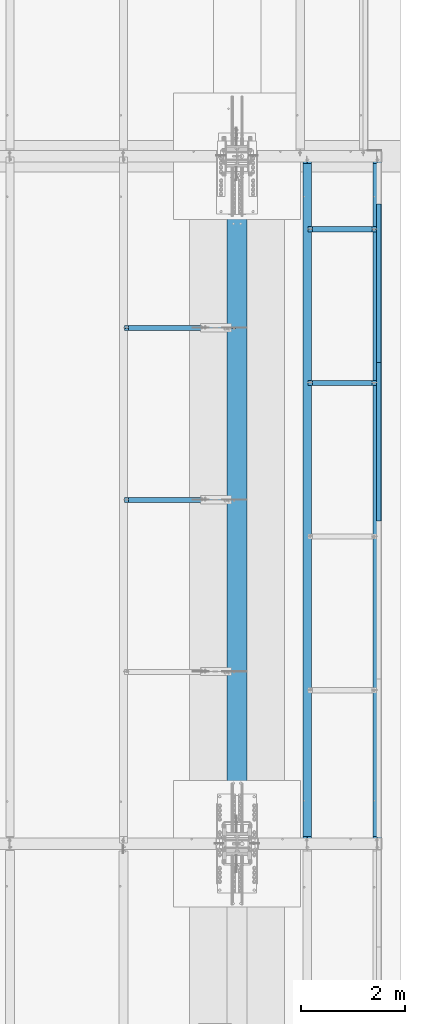
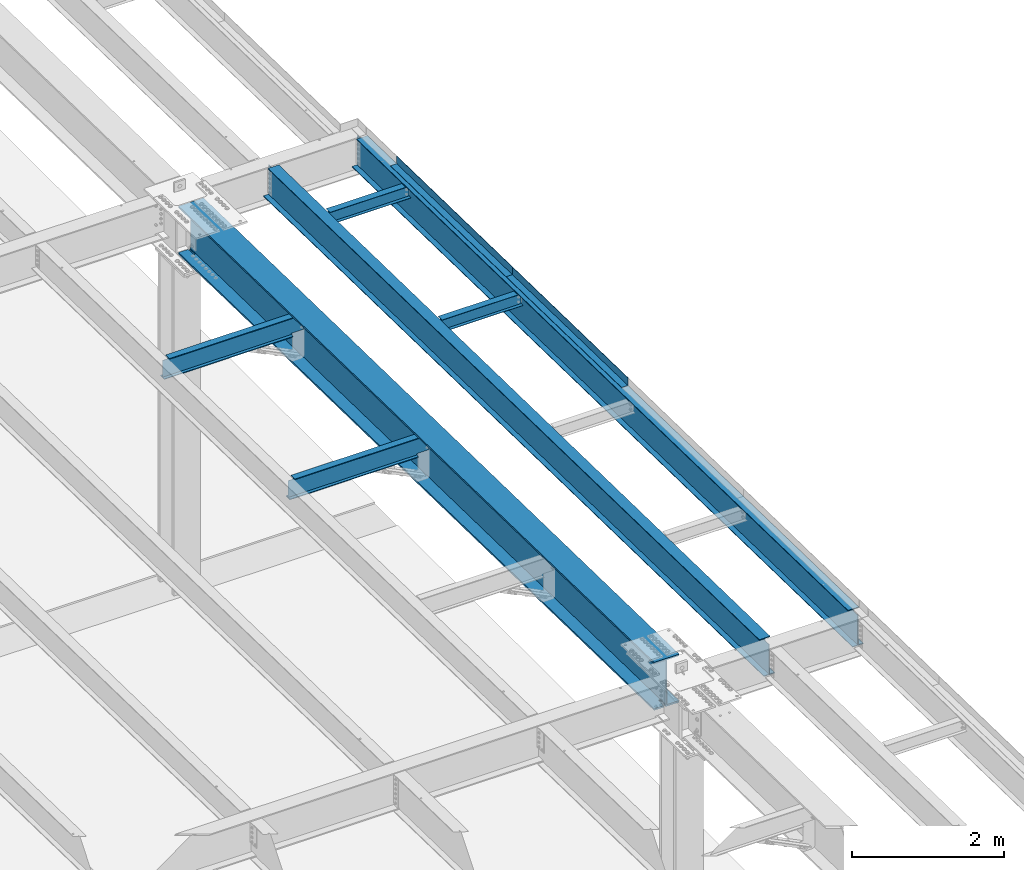
# One storey, part 1116 of 1763: 9 beams, 7 elements without a shape of their own.
"""IFC2X3 building model written with IfcOpenShell, lengths in millimetres."""

import ifcopenshell
import ifcopenshell.guid

model = None  # the IFC model being written
_history = None  # IfcOwnerHistory: only IFC2X3 demands one
_inside = {}  # id of a spatial element -> (the spatial element, [elements in it])
_under = {}  # id of a project, library or spatial element -> (it, [spatial elements below it])
_declared = {}  # id of a project -> (the project, [libraries it declares])
_typed = {}  # id of a type object -> (the type object, [elements of that type])
_made_of = {}  # id of a material, layer set ... -> (it, [elements and type objects made of it])


def new_model(schema):
    """Start an empty IFC model of exactly this schema.

    Asked for "IFC4X3", IfcOpenShell would pick the latest addendum, in which some entities
    have other attributes; the version numbers below select the first issue.
    IFC2X3 requires an IfcOwnerHistory on every rooted entity: one is made here for all.
    """
    global model, _history
    if schema == "IFC4X3":
        model = ifcopenshell.file(schema_version=(4, 3, 0, 0))
    else:
        model = ifcopenshell.file(schema=schema)
    _inside.clear()
    _under.clear()
    _declared.clear()
    _typed.clear()
    _made_of.clear()
    _history = None
    if model.schema == "IFC2X3":
        org = make("IfcOrganization", Name="unknown")
        user = make(
            "IfcPersonAndOrganization",
            ThePerson=make("IfcPerson", FamilyName="unknown"),
            TheOrganization=org,
        )
        app = make(
            "IfcApplication",
            ApplicationDeveloper=org,
            Version="unknown",
            ApplicationFullName="unknown",
            ApplicationIdentifier="unknown",
        )
        _history = make(
            "IfcOwnerHistory",
            OwningUser=user,
            OwningApplication=app,
            ChangeAction="ADDED",
            CreationDate=0,
        )
    return model


def make(cls, **values):
    """One entity of the class cls with the attributes given. An attribute that is None is left unset."""
    return model.create_entity(
        cls, **{name: value for name, value in values.items() if value is not None}
    )


def rooted(cls, **values):
    """An entity with a GlobalId (a new one), such as an element, a storey or a relation."""
    return make(cls, GlobalId=ifcopenshell.guid.new(), OwnerHistory=_history, **values)


def si_unit(unit_type, name, prefix=None):
    """IfcSIUnit, for example si_unit("LENGTHUNIT", "METRE", prefix="MILLI")."""
    return make("IfcSIUnit", UnitType=unit_type, Prefix=prefix, Name=name)


def assignment(units):
    """IfcUnitAssignment: the units of a project."""
    return None if units is None else make("IfcUnitAssignment", Units=units)


def point(xyz):
    """IfcCartesianPoint."""
    return None if xyz is None else make("IfcCartesianPoint", Coordinates=xyz)


def direction(xyz):
    """IfcDirection."""
    return None if xyz is None else make("IfcDirection", DirectionRatios=xyz)


def frame(location, z_axis=None, x_axis=None):
    """IfcAxis2Placement3D, a coordinate frame: its origin and axes. An axis left out is left unset."""
    return make(
        "IfcAxis2Placement3D",
        Location=point(location),
        Axis=direction(z_axis),
        RefDirection=direction(x_axis),
    )


def origin_with_axes():
    """The frame at (0, 0, 0) with the z axis (0, 0, 1) and the x axis (1, 0, 0) written out."""
    return frame((0.0, 0.0, 0.0), z_axis=(0.0, 0.0, 1.0), x_axis=(1.0, 0.0, 0.0))


def place(relative_to, where):
    """IfcLocalPlacement: puts the frame where relative to a parent placement (None: the world)."""
    return make(
        "IfcLocalPlacement", PlacementRelTo=relative_to, RelativePlacement=where
    )


def context(
    kind, dimensions, precision=None, world=None, true_north=None, identifier=None
):
    """IfcGeometricRepresentationContext, for example the 3D "Model" context."""
    return make(
        "IfcGeometricRepresentationContext",
        ContextIdentifier=identifier,
        ContextType=kind,
        CoordinateSpaceDimension=dimensions,
        Precision=precision,
        WorldCoordinateSystem=world,
        TrueNorth=true_north,
    )


def subcontext(parent, identifier, kind, view, scale=None):
    """IfcGeometricRepresentationSubContext, for example "Body" below "Model"."""
    return make(
        "IfcGeometricRepresentationSubContext",
        ContextIdentifier=identifier,
        ContextType=kind,
        ParentContext=parent,
        TargetScale=scale,
        TargetView=view,
    )


def project(units=None, contexts=None):
    """IfcProject with its units and contexts."""
    return rooted(
        "IfcProject",
        Name="project",
        RepresentationContexts=contexts,
        UnitsInContext=assignment(units),
    )


def spatial(cls, under=None, at=None, **own):
    """A site, building, storey or space (cls), placed at a placement, below another one or the project."""
    s = rooted(cls, ObjectPlacement=at, **own)
    if under is not None:
        _under.setdefault(under.id(), (under, []))[1].append(s)
    return s


def faces_of(points, faces, orient=None, outer=None):
    """IfcFace entities. A face is a list of loops; a loop is a list of indices into points, from 0.

    orient and outer hold one flag for each loop. By default every Orientation is true, the
    first loop of a face is its IfcFaceOuterBound and the others are IfcFaceBound.
    """
    made = []
    for i, loops in enumerate(faces):
        bounds = []
        for j, loop in enumerate(loops):
            is_outer = j == 0 if outer is None else outer[i][j]
            bounds.append(
                make(
                    "IfcFaceOuterBound" if is_outer else "IfcFaceBound",
                    Bound=make("IfcPolyLoop", Polygon=[points[k] for k in loop]),
                    Orientation=True if orient is None else orient[i][j],
                )
            )
        made.append(make("IfcFace", Bounds=bounds))
    return made


def faceted_brep(points, faces, orient=None, outer=None, voids=None):
    """IfcFacetedBrep: a solid bounded by flat faces; with voids (closed shells), ...WithVoids."""
    shared = [point(p) for p in points]
    hull = make("IfcClosedShell", CfsFaces=faces_of(shared, faces, orient, outer))
    if voids is None:
        return make("IfcFacetedBrep", Outer=hull)
    return make(
        "IfcFacetedBrepWithVoids",
        Outer=hull,
        Voids=[
            make(cls, CfsFaces=faces_of(shared, fs, o, b)) for cls, fs, o, b in voids
        ],
    )


def shape(context_of_items, identifier, shape_type, items):
    """IfcShapeRepresentation: the items that make up one representation, for example the "Body"."""
    return make(
        "IfcShapeRepresentation",
        ContextOfItems=context_of_items,
        RepresentationIdentifier=identifier,
        RepresentationType=shape_type,
        Items=items,
    )


def material(Name=None, Category=None):
    """IfcMaterial."""
    return make("IfcMaterial", Name=Name, Category=Category)


def made_of(thing, what):
    """Note that an element or type object is made of a material, layer set ...; save() writes the relation."""
    if what is not None:
        _made_of.setdefault(what.id(), (what, []))[1].append(thing)
    return thing


def type_object(cls, material=None, **own):
    """A type object (cls), such as IfcWallType, which elements share."""
    return made_of(rooted(cls, **own), material)


def element(
    cls,
    number,
    at=None,
    inside=None,
    cuts=None,
    type_object=None,
    material=None,
    context=None,
    identifier="Body",
    shape_type=None,
    held_by="IfcProductDefinitionShape",
    body=None,
    shapes=None,
    **own,
):
    """One element of the class cls, such as IfcWall. Its Tag is "e" and its number.

    at: its placement. inside: the storey or other place that contains it. cuts: it is an
    opening in that element (IfcRelVoidsElement). A single representation is given by context,
    identifier, shape_type and body (its items); several are given by shapes. held_by: the class
    of the entity that holds the representations. save() writes the other relations.
    """
    e = rooted(cls, Tag="e%d" % number, ObjectPlacement=at, **own)
    if body is not None:
        shapes = [shape(context, identifier, shape_type, body)]
    if shapes is not None:
        e.Representation = make(held_by, Representations=shapes)
    if inside is not None:
        _inside.setdefault(inside.id(), (inside, []))[1].append(e)
    if cuts is not None:
        rooted(
            "IfcRelVoidsElement", RelatingBuildingElement=cuts, RelatedOpeningElement=e
        )
    if type_object is not None:
        _typed.setdefault(type_object.id(), (type_object, []))[1].append(e)
    return made_of(e, material)


def aggregate(whole, parts):
    """IfcRelAggregates: a whole, such as a stair, and the parts it consists of."""
    return rooted("IfcRelAggregates", RelatingObject=whole, RelatedObjects=parts)


def save(model, path):
    """Write the relations noted so far, then the file.

    IfcRelAggregates (storeys below a building ...), IfcRelContainedInSpatialStructure (elements
    in a storey), IfcRelDefinesByType, IfcRelAssociatesMaterial and IfcRelDeclares: one each for
    every whole, place, type object, material and project.
    """
    for whole, parts in _under.values():
        aggregate(whole, parts)
    for where, things in _inside.values():
        rooted(
            "IfcRelContainedInSpatialStructure",
            RelatedElements=things,
            RelatingStructure=where,
        )
    for kind, things in _typed.values():
        rooted("IfcRelDefinesByType", RelatedObjects=things, RelatingType=kind)
    for what, things in _made_of.values():
        rooted("IfcRelAssociatesMaterial", RelatedObjects=things, RelatingMaterial=what)
    for by, libraries in _declared.values():
        rooted("IfcRelDeclares", RelatingContext=by, RelatedDefinitions=libraries)
    model.write(path)


model = new_model("IFC2X3")

# Units and contexts
model_context = context("Model", 3, precision=1e-05, world=origin_with_axes())
body_context = subcontext(model_context, "Body", "Model", "MODEL_VIEW")
ifc_project = project(units=[si_unit("LENGTHUNIT", "METRE", prefix="MILLI"), si_unit("AREAUNIT", "SQUARE_METRE"), si_unit("VOLUMEUNIT", "CUBIC_METRE"), si_unit("MASSUNIT", "GRAM", prefix="KILO"), si_unit("TIMEUNIT", "SECOND"), si_unit("PLANEANGLEUNIT", "RADIAN"), si_unit("SOLIDANGLEUNIT", "STERADIAN"), si_unit("THERMODYNAMICTEMPERATUREUNIT", "DEGREE_CELSIUS"), si_unit("LUMINOUSINTENSITYUNIT", "LUMEN")], contexts=[model_context])

# Site, building, storey
site_placement = place(None, origin_with_axes())
site = spatial("IfcSite", under=ifc_project, at=site_placement, CompositionType="ELEMENT")
building_placement = place(site_placement, origin_with_axes())
building = spatial("IfcBuilding", under=site, at=building_placement, Name="Undefined", CompositionType="ELEMENT")
storey_placement = place(building_placement, origin_with_axes())
storey = spatial("IfcBuildingStorey", under=building, at=storey_placement, Name="Undefined", CompositionType="ELEMENT", Elevation=0.0)

# Assembly, beams
assembly_1_placement = place(storey_placement, origin_with_axes())
assembly_1 = element("IfcElementAssembly", 1, at=assembly_1_placement, inside=storey, Name="BEAM", AssemblyPlace="NOTDEFINED", PredefinedType="RIGID_FRAME")
ifc_material_1 = material(Name="STEEL/A36")
beam_type_1 = type_object("IfcBeamType", PredefinedType="NOTDEFINED")
beam_1_placement = place(assembly_1_placement, frame((-21348.1372736983, 11243.5716910925, 11686.0728087312), z_axis=(0.0, -0.999781542838788, 0.0209013539966307), x_axis=(1.0, 0.0, 0.0)))
beam_1 = element("IfcBeam", 2, at=beam_1_placement, type_object=beam_type_1, material=ifc_material_1, Name="BENT_PLATE", context=body_context, shape_type="Brep", body=[
    faceted_brep([(0.0, -3.17499999999927, -1523.99999999999), (0.0, -3.17499999999927, 1524.0), (0.0, 3.17499999999927, 1524.0), (0.0, 3.17499999999927, -1523.99999999999), (95.2499984741262, 3.17499999910251, 1523.99999999978), (95.2499984741262, 3.17500000090149, -1523.99999999977), (101.599998474125, -3.17499999909887, -1523.99999999978), (101.599999809252, -3.17500000000655, 1524.0), (95.2499984741262, 123.825003587437, 1523.99999999985), (95.2499984741262, 123.825003589236, -1523.9999999997), (101.599998474125, 123.825003587437, 1523.99999999985), (101.599998474125, 123.825003589236, -1523.9999999997)], [[[0, 1, 2, 3]], [[3, 2, 4, 5]], [[1, 0, 6, 7]], [[5, 4, 8, 9]], [[4, 2, 1, 7, 10, 8]], [[7, 6, 11, 10]], [[6, 0, 3, 5, 9, 11]], [[10, 11, 9, 8]]]),
])
beam_2_placement = place(assembly_1_placement, frame((-21348.1372736983, 8196.23754864728, 11749.7801418084), z_axis=(0.0, -0.999781542838788, 0.0209013539966307), x_axis=(1.0, 0.0, 0.0)))
beam_2 = element("IfcBeam", 3, at=beam_2_placement, type_object=beam_type_1, material=ifc_material_1, Name="BENT_PLATE", context=body_context, shape_type="Brep", body=[
    faceted_brep([(0.0, -3.17499999999927, -1523.99999999999), (0.0, -3.17499999999927, 1524.0), (0.0, 3.17499999999927, 1524.0), (0.0, 3.17499999999927, -1523.99999999999), (95.2499984741262, 3.17499999910251, 1523.99999999978), (95.2499984741262, 3.17500000090149, -1523.99999999977), (101.599998474125, -3.17499999909887, -1523.99999999978), (101.599999809252, -3.17500000000655, 1524.0), (95.2499984741262, 123.825003587437, 1523.99999999985), (95.2499984741262, 123.825003589236, -1523.9999999997), (101.599998474125, 123.825003587437, 1523.99999999985), (101.599998474125, 123.825003589236, -1523.9999999997)], [[[0, 1, 2, 3]], [[3, 2, 4, 5]], [[1, 0, 6, 7]], [[5, 4, 8, 9]], [[4, 2, 1, 7, 10, 8]], [[7, 6, 11, 10]], [[6, 0, 3, 5, 9, 11]], [[10, 11, 9, 8]]]),
])

# Assembly, beam
assembly_2_placement = place(storey_placement, origin_with_axes())
assembly_2 = element("IfcElementAssembly", 4, at=assembly_2_placement, inside=storey, Name="BEAM", AssemblyPlace="NOTDEFINED", PredefinedType="RIGID_FRAME")
ifc_material_2 = material(Name="STEEL/A992")
beam_type_2 = type_object("IfcBeamType", Name="W8X10", PredefinedType="NOTDEFINED")
beam_3_placement = place(assembly_2_placement, frame((-22678.4622736983, 9326.87987676897, 11622.9548265527), z_axis=(0.0, 0.0, 1.0), x_axis=(1.0, 0.0, 0.0)))
beam_3 = element("IfcBeam", 5, at=beam_3_placement, type_object=beam_type_2, material=ifc_material_2, Name="BEAM", ObjectType="W8X10", context=body_context, shape_type="Brep", body=[
    faceted_brep([(1249.3625, -50.7999999999993, 100.012500000001), (1249.3625, -50.7999999999993, 95.25), (1249.3625, -2.38125000000036, 95.25), (1249.3625, -2.38124999999991, 83.8775014834882), (1249.3625, 2.38124999999991, 83.8775014834882), (1249.3625, 2.38125000000036, 95.25), (1249.3625, 50.7999999999993, 95.25), (1249.3625, 50.7999999999993, 100.012500000001), (1250.32922992259, -2.38124999999991, 79.0174219654418), (1250.32922992259, 2.38124999999991, 79.0174219654418), (1253.08224382306, -2.38124999999991, 74.8972454972882), (1253.08224382306, 2.38124999999991, 74.8972454972882), (1257.20242029122, -2.38124999999991, 72.1442315968106), (1257.20242029122, 2.38124999999991, 72.1442315968106), (1262.06249980926, -2.38124999999991, 71.1775016742231), (1262.06249980926, 2.38124999999991, 71.1775016742231), (1331.9125, -2.38124999999991, 71.1775016742231), (1331.9125, 2.38124999999991, 71.1775016742231), (100.012500000012, -50.7999999999993, 100.012500000001), (100.012500000012, 50.7999999999993, 100.012500000001), (100.012500000012, 50.7999999999993, 95.25), (100.012500000012, 2.38124999999854, 95.25), (100.012500000012, 2.38124999999854, 83.877501483119), (100.012500000012, -2.38124999999854, 83.877501483119), (100.012500000012, -2.38124999999854, 95.25), (100.012500000012, -50.7999999999993, 95.25), (99.0457700774241, 2.38124999999854, 79.0174219650726), (99.0457700774241, -2.38124999999854, 79.0174219650726), (96.2927561769466, 2.38124999999854, 74.8972454969189), (96.2927561769466, -2.38124999999854, 74.8972454969189), (92.1725797087929, 2.38124999999854, 72.1442315964414), (92.1725797087929, -2.38124999999854, 72.1442315964414), (87.3125001907465, 2.38124999999854, 71.1775016738538), (87.3125001907465, -2.38124999999854, 71.1775016738538), (17.4625000000015, 2.38124999999854, 71.1775016738538), (17.4625000000015, -2.38124999999854, 71.1775016738538), (17.462499935149, 2.38124999999854, -95.25), (17.4625000000015, 50.7999999999993, -95.25), (17.4625000000015, 50.7999999999993, -100.012500000001), (17.4624996160601, -50.8000000000029, -100.012500000001), (17.4624996160601, -50.8000000000029, -95.25), (17.4624999065727, -2.38124999999854, -95.25), (1331.91249999999, 2.38125000000036, -95.25), (1331.91249999999, 50.7999999999993, -95.25), (1331.91249999999, 50.7999999999993, -100.012500000001), (1331.91249999999, -50.7999999999993, -100.012500000001), (1331.91249999999, -50.7999999999993, -95.25), (1331.91249999999, -2.38125000000036, -95.25)], [[[0, 1, 2, 3, 4, 5, 6, 7]], [[8, 9, 4, 3]], [[10, 11, 9, 8]], [[12, 13, 11, 10]], [[14, 15, 13, 12]], [[16, 17, 15, 14]], [[18, 19, 20, 21, 22, 23, 24, 25]], [[23, 22, 26, 27]], [[27, 26, 28, 29]], [[29, 28, 30, 31]], [[31, 30, 32, 33]], [[33, 32, 34, 35]], [[36, 37, 38, 39, 40, 41, 35, 34]], [[37, 36, 42, 43]], [[38, 37, 43, 44]], [[39, 38, 44, 45]], [[40, 39, 45, 46]], [[41, 40, 46, 47]], [[12, 10, 8, 3, 2, 24, 23, 27, 29, 31, 33, 35, 41, 47, 16, 14]], [[25, 24, 2, 1]], [[18, 25, 1, 0]], [[19, 18, 0, 7]], [[20, 19, 7, 6]], [[21, 20, 6, 5]], [[42, 36, 34, 32, 30, 28, 26, 22, 21, 5, 4, 9, 11, 13, 15, 17]], [[47, 46, 45, 44, 43, 42, 17, 16]]]),
])
aggregate(assembly_2, [beam_3])

assembly_3_placement = place(storey_placement, origin_with_axes())
assembly_3 = element("IfcElementAssembly", 6, at=assembly_3_placement, inside=storey, Name="BEAM", AssemblyPlace="NOTDEFINED", PredefinedType="RIGID_FRAME")
beam_4_placement = place(assembly_3_placement, frame((-22678.4622736983, 12283.438104308, 11561.145247768), z_axis=(0.0, 0.0, 1.0), x_axis=(1.0, 0.0, 0.0)))
beam_4 = element("IfcBeam", 7, at=beam_4_placement, type_object=beam_type_2, material=ifc_material_2, Name="BEAM", ObjectType="W8X10", context=body_context, shape_type="Brep", body=[
    faceted_brep([(87.3125001907465, -2.38124999999854, 71.1775016738538), (87.3125001907465, 2.38124999999854, 71.1775016738538), (17.4625000000015, 2.38124999999854, 71.1775016738538), (17.4625000000015, -2.38124999999854, 71.1775016738538), (92.1725797087929, -2.38124999999854, 72.1442315964414), (92.1725797087929, 2.38124999999854, 72.1442315964414), (96.2927561769466, -2.38124999999854, 74.8972454969189), (96.2927561769466, 2.38124999999854, 74.8972454969189), (99.0457700774241, -2.38124999999854, 79.0174219650726), (99.0457700774241, 2.38124999999854, 79.0174219650726), (100.012500000012, -2.38124999999854, 83.877501483119), (100.012500000012, 2.38124999999854, 83.877501483119), (100.012500000012, -50.7999999999993, 100.012500000001), (100.012500000012, 50.7999999999993, 100.012500000001), (100.012500000012, 50.7999999999993, 95.25), (100.012500000012, 2.38124999999854, 95.25), (100.012500000012, -2.38124999999854, 95.25), (100.012500000012, -50.7999999999993, 95.25), (17.4624999065727, -2.38124999999854, -95.25), (17.4624996160601, -50.8000000000029, -95.25), (1331.91249999999, -50.7999999999993, -95.25), (1331.91249999999, -2.38125000000036, -95.25), (17.4624996160601, -50.8000000000029, -100.012500000001), (1331.91249999999, -50.7999999999993, -100.012500000001), (17.4625000000015, 50.7999999999993, -100.012500000001), (1331.91249999999, 50.7999999999993, -100.012500000001), (17.4625000000015, 50.7999999999993, -95.25), (1331.91249999999, 50.7999999999993, -95.25), (17.462499935149, 2.38124999999854, -95.25), (1331.91249999999, 2.38125000000036, -95.25), (1331.9125, 2.38124999999991, 71.1775016742231), (1331.9125, -2.38124999999991, 71.1775016742231), (1262.06249980926, 2.38124999999991, 71.1775016742231), (1262.06249980926, -2.38124999999991, 71.1775016742231), (1257.20242029122, 2.38124999999991, 72.1442315968106), (1257.20242029122, -2.38124999999991, 72.1442315968106), (1253.08224382306, 2.38124999999991, 74.8972454972882), (1253.08224382306, -2.38124999999991, 74.8972454972882), (1250.32922992259, 2.38124999999991, 79.0174219654418), (1250.32922992259, -2.38124999999991, 79.0174219654418), (1249.3625, 2.38124999999991, 83.8775014834882), (1249.3625, -2.38124999999991, 83.8775014834882), (1249.3625, -50.7999999999993, 100.012500000001), (1249.3625, -50.7999999999993, 95.25), (1249.3625, -2.38125000000036, 95.25), (1249.3625, 2.38125000000036, 95.25), (1249.3625, 50.7999999999993, 95.25), (1249.3625, 50.7999999999993, 100.012500000001)], [[[0, 1, 2, 3]], [[4, 5, 1, 0]], [[6, 7, 5, 4]], [[8, 9, 7, 6]], [[10, 11, 9, 8]], [[12, 13, 14, 15, 11, 10, 16, 17]], [[18, 19, 20, 21]], [[19, 22, 23, 20]], [[22, 24, 25, 23]], [[24, 26, 27, 25]], [[26, 28, 29, 27]], [[21, 20, 23, 25, 27, 29, 30, 31]], [[31, 30, 32, 33]], [[33, 32, 34, 35]], [[35, 34, 36, 37]], [[37, 36, 38, 39]], [[39, 38, 40, 41]], [[42, 43, 44, 41, 40, 45, 46, 47]], [[12, 17, 43, 42]], [[17, 16, 44, 43]], [[35, 37, 39, 41, 44, 16, 10, 8, 6, 4, 0, 3, 18, 21, 31, 33]], [[28, 26, 24, 22, 19, 18, 3, 2]], [[29, 28, 2, 1, 5, 7, 9, 11, 15, 45, 40, 38, 36, 34, 32, 30]], [[15, 14, 46, 45]], [[14, 13, 47, 46]], [[13, 12, 42, 47]]]),
])
aggregate(assembly_3, [beam_4])

assembly_4_placement = place(storey_placement, origin_with_axes())
assembly_4 = element("IfcElementAssembly", 8, at=assembly_4_placement, inside=storey, Name="BEAM", AssemblyPlace="NOTDEFINED", PredefinedType="RIGID_FRAME")
beam_type_3 = type_object("IfcBeamType", Name="W12X22", PredefinedType="NOTDEFINED")
beam_5_placement = place(assembly_4_placement, frame((-26212.2372736983, 10382.2499999995, 11545.3288399719), z_axis=(0.0, 0.0, 1.0), x_axis=(1.0, 0.0, 0.0)))
beam_5 = element("IfcBeam", 9, at=beam_5_placement, type_object=beam_type_3, material=ifc_material_2, Name="BEAM", ObjectType="W12X22", context=body_context, shape_type="Brep", body=[
    faceted_brep([(1973.26249999999, -3.17499999999927, -144.4625), (1973.26249999999, -50.7999999999993, -144.4625), (1973.26249999999, -50.7999999999993, -155.575000000001), (1973.26249999999, 50.7999999999993, -155.575000000001), (1973.26249999999, 50.7999999999993, -144.4625), (1973.26249999999, 3.17499999999927, -144.4625), (1973.26249999999, 3.17499999999927, -136.524999809046), (1973.26249999999, -3.17499999999927, -136.524999809046), (1974.22922992258, 3.17499999999927, -131.664920290999), (1974.22922992258, -3.17499999999927, -131.664920290999), (1976.98224382305, 3.17499999999927, -127.544743822846), (1976.98224382305, -3.17499999999927, -127.544743822846), (1981.10242029121, 3.17499999999927, -124.791729922368), (1981.10242029121, -3.17499999999927, -124.791729922368), (1985.96249980925, 3.17499999999927, -123.824999999781), (1985.96249980925, -3.17499999999927, -123.824999999781), (2163.76249999999, -3.17499999999927, -123.824999999781), (2163.76249999999, 3.17499999999927, -123.824999999781), (92.8687500000051, 3.17499999999927, 144.4625), (92.8687500000051, 50.7999999999993, 144.4625), (1973.26249999999, 50.7999999999993, 144.4625), (1973.26249999999, 3.17499999999927, 144.4625), (16.6687499999898, 3.17499999999927, -144.4625), (16.6687499999898, 50.7999999999993, -144.4625), (16.6687499999898, 50.7999999999993, -155.575000000001), (16.6687499999898, -50.7999999999993, -155.575000000001), (16.6687499999898, -50.7999999999993, -144.4625), (16.6687499999898, -3.17499999999927, -144.4625), (16.6687499999898, -3.17499999999927, 123.565001683279), (16.6687499999898, 3.17499999999927, 123.565001683279), (80.16875019074, -3.17499999999927, 123.565001672911), (80.16875019074, 3.17499999999927, 123.565001672911), (85.0288297087864, -3.17499999999927, 124.531731595498), (85.0288297087864, 3.17499999999927, 124.531731595498), (89.14900617694, -3.17499999999927, 127.284745495976), (89.14900617694, 3.17499999999927, 127.284745495976), (91.9020200774175, -3.17499999999927, 131.404921964129), (91.9020200774175, 3.17499999999927, 131.404921964129), (92.8687500000051, -3.17499999999927, 136.265001482176), (92.8687500000051, 3.17499999999927, 136.265001482176), (92.8687500000051, -50.7999999999993, 155.575000000001), (92.8687500000051, 50.7999999999993, 155.575000000001), (92.8687500000051, -3.17499999999927, 144.4625), (92.8687500000051, -50.7999999999993, 144.4625), (1973.26249999999, -3.17499999999927, 144.4625), (1973.26249999999, -50.7999999999993, 144.4625), (1973.26249999999, -50.7999999999993, 155.575000000001), (1973.26249999999, 50.7999999999993, 155.575000000001), (1973.26249999999, -3.17499999999927, 123.824999809485), (1973.26249999999, 3.17499999999927, 123.824999809485), (1974.22922992258, -3.17499999999927, 118.964920291439), (1974.22922992258, 3.17499999999927, 118.964920291439), (1976.98224382305, -3.17499999999927, 114.844743823285), (1976.98224382305, 3.17499999999927, 114.844743823285), (1981.10242029121, -3.17499999999927, 112.091729922808), (1981.10242029121, 3.17499999999927, 112.091729922808), (1985.96249980925, -3.17499999999927, 111.12500000022), (1985.96249980925, 3.17499999999927, 111.12500000022), (2163.76249999999, -3.17499999999927, 111.12500000022), (2163.76249999999, 3.17499999999927, 111.12500000022)], [[[0, 1, 2, 3, 4, 5, 6, 7]], [[7, 6, 8, 9]], [[9, 8, 10, 11]], [[11, 10, 12, 13]], [[13, 12, 14, 15]], [[16, 15, 14, 17]], [[18, 19, 20, 21]], [[22, 23, 24, 25, 26, 27, 28, 29]], [[30, 31, 29, 28]], [[32, 33, 31, 30]], [[34, 35, 33, 32]], [[36, 37, 35, 34]], [[38, 39, 37, 36]], [[40, 41, 19, 18, 39, 38, 42, 43]], [[43, 42, 44, 45]], [[40, 43, 45, 46]], [[41, 40, 46, 47]], [[19, 41, 47, 20]], [[46, 45, 44, 48, 49, 21, 20, 47]], [[50, 51, 49, 48]], [[52, 53, 51, 50]], [[54, 55, 53, 52]], [[56, 57, 55, 54]], [[58, 59, 57, 56]], [[59, 58, 16, 17]], [[12, 10, 8, 6, 5, 22, 29, 31, 33, 35, 37, 39, 18, 21, 49, 51, 53, 55, 57, 59, 17, 14]], [[23, 22, 5, 4]], [[24, 23, 4, 3]], [[25, 24, 3, 2]], [[26, 25, 2, 1]], [[27, 26, 1, 0]], [[58, 56, 54, 52, 50, 48, 44, 42, 38, 36, 34, 32, 30, 28, 27, 0, 7, 9, 11, 13, 15, 16]]]),
])
aggregate(assembly_4, [beam_5])

assembly_5_placement = place(storey_placement, origin_with_axes())
assembly_5 = element("IfcElementAssembly", 10, at=assembly_5_placement, inside=storey, Name="BEAM", AssemblyPlace="NOTDEFINED", PredefinedType="RIGID_FRAME")
beam_6_placement = place(assembly_5_placement, frame((-26212.2372736983, 7073.90002966673, 11614.5137881522), z_axis=(0.0, 0.0, 1.0), x_axis=(1.0, 0.0, 0.0)))
beam_6 = element("IfcBeam", 11, at=beam_6_placement, type_object=beam_type_3, material=ifc_material_2, Name="BEAM", ObjectType="W12X22", context=body_context, shape_type="Brep", body=[
    faceted_brep([(1973.26249999999, -3.17499999999927, -144.4625), (1973.26249999999, -50.7999999999993, -144.4625), (1973.26249999999, -50.7999999999993, -155.575000000001), (1973.26249999999, 50.7999999999993, -155.575000000001), (1973.26249999999, 50.7999999999993, -144.4625), (1973.26249999999, 3.17499999999927, -144.4625), (1973.26249999999, 3.17499999999927, -136.524999809046), (1973.26249999999, -3.17499999999927, -136.524999809046), (1974.22922992258, 3.17499999999927, -131.664920290999), (1974.22922992258, -3.17499999999927, -131.664920290999), (1976.98224382305, 3.17499999999927, -127.544743822846), (1976.98224382305, -3.17499999999927, -127.544743822846), (1981.10242029121, 3.17499999999927, -124.791729922368), (1981.10242029121, -3.17499999999927, -124.791729922368), (1985.96249980925, 3.17499999999927, -123.824999999781), (1985.96249980925, -3.17499999999927, -123.824999999781), (2163.76249999999, -3.17499999999927, -123.824999999781), (2163.76249999999, 3.17499999999927, -123.824999999781), (92.8687500000051, 3.17499999999927, 144.4625), (92.8687500000051, 50.7999999999993, 144.4625), (1973.26249999999, 50.7999999999993, 144.4625), (1973.26249999999, 3.17499999999927, 144.4625), (16.6687499999898, 3.17499999999927, -144.4625), (16.6687499999898, 50.7999999999993, -144.4625), (16.6687499999898, 50.7999999999993, -155.575000000001), (16.6687499999898, -50.7999999999993, -155.575000000001), (16.6687499999898, -50.7999999999993, -144.4625), (16.6687499999898, -3.17499999999927, -144.4625), (16.6687499999898, -3.17499999999927, 123.565001683279), (16.6687499999898, 3.17499999999927, 123.565001683279), (80.16875019074, -3.17499999999927, 123.565001672911), (80.16875019074, 3.17499999999927, 123.565001672911), (85.0288297087864, -3.17499999999927, 124.531731595498), (85.0288297087864, 3.17499999999927, 124.531731595498), (89.14900617694, -3.17499999999927, 127.284745495976), (89.14900617694, 3.17499999999927, 127.284745495976), (91.9020200774175, -3.17499999999927, 131.404921964129), (91.9020200774175, 3.17499999999927, 131.404921964129), (92.8687500000051, -3.17499999999927, 136.265001482176), (92.8687500000051, 3.17499999999927, 136.265001482176), (92.8687500000051, -50.7999999999993, 155.575000000001), (92.8687500000051, 50.7999999999993, 155.575000000001), (92.8687500000051, -3.17499999999927, 144.4625), (92.8687500000051, -50.7999999999993, 144.4625), (1973.26249999999, -3.17499999999927, 144.4625), (1973.26249999999, -50.7999999999993, 144.4625), (1973.26249999999, -50.7999999999993, 155.575000000001), (1973.26249999999, 50.7999999999993, 155.575000000001), (1973.26249999999, -3.17499999999927, 123.824999809485), (1973.26249999999, 3.17499999999927, 123.824999809485), (1974.22922992258, -3.17499999999927, 118.964920291439), (1974.22922992258, 3.17499999999927, 118.964920291439), (1976.98224382305, -3.17499999999927, 114.844743823285), (1976.98224382305, 3.17499999999927, 114.844743823285), (1981.10242029121, -3.17499999999927, 112.091729922808), (1981.10242029121, 3.17499999999927, 112.091729922808), (1985.96249980925, -3.17499999999927, 111.12500000022), (1985.96249980925, 3.17499999999927, 111.12500000022), (2163.76249999999, -3.17499999999927, 111.12500000022), (2163.76249999999, 3.17499999999927, 111.12500000022)], [[[0, 1, 2, 3, 4, 5, 6, 7]], [[7, 6, 8, 9]], [[9, 8, 10, 11]], [[11, 10, 12, 13]], [[13, 12, 14, 15]], [[16, 15, 14, 17]], [[18, 19, 20, 21]], [[22, 23, 24, 25, 26, 27, 28, 29]], [[30, 31, 29, 28]], [[32, 33, 31, 30]], [[34, 35, 33, 32]], [[36, 37, 35, 34]], [[38, 39, 37, 36]], [[40, 41, 19, 18, 39, 38, 42, 43]], [[43, 42, 44, 45]], [[40, 43, 45, 46]], [[41, 40, 46, 47]], [[19, 41, 47, 20]], [[46, 45, 44, 48, 49, 21, 20, 47]], [[50, 51, 49, 48]], [[52, 53, 51, 50]], [[54, 55, 53, 52]], [[56, 57, 55, 54]], [[58, 59, 57, 56]], [[59, 58, 16, 17]], [[12, 10, 8, 6, 5, 22, 29, 31, 33, 35, 37, 39, 18, 21, 49, 51, 53, 55, 57, 59, 17, 14]], [[23, 22, 5, 4]], [[24, 23, 4, 3]], [[25, 24, 3, 2]], [[26, 25, 2, 1]], [[27, 26, 1, 0]], [[58, 56, 54, 52, 50, 48, 44, 42, 38, 36, 34, 32, 30, 28, 27, 0, 7, 9, 11, 13, 15, 16]]]),
])
aggregate(assembly_5, [beam_6])

assembly_6_placement = place(storey_placement, origin_with_axes())
assembly_6 = element("IfcElementAssembly", 12, at=assembly_6_placement, inside=storey, Name="BEAM", AssemblyPlace="NOTDEFINED", PredefinedType="RIGID_FRAME")
beam_type_4 = type_object("IfcBeamType", Name="W30X173", PredefinedType="NOTDEFINED")
beam_7_placement = place(assembly_6_placement, frame((-24027.8372736984, 449.103859770058, 11521.1307908923), z_axis=(0.0, 0.0209013539966291, 0.999781542838788), x_axis=(0.0, 0.999781542776098, -0.0209013569953182)))
beam_7 = element("IfcBeam", 13, at=beam_7_placement, type_object=beam_type_4, material=ifc_material_2, Name="BEAM", ObjectType="W30X173", context=body_context, shape_type="Brep", body=[
    faceted_brep([(12949.2086283733, 41.275000381469, -387.35000000479), (12948.6444297751, 41.275000381469, -360.362500004767), (12804.7461389585, 41.275000381469, -360.36250000472), (12804.7461316162, 41.275000381469, -387.350000004739), (12800.4935692434, 40.4291116719833, -360.362500004718), (12800.493561901, 40.4291116719833, -387.350000004739), (12796.8884147177, 38.0202244315406, -360.362500004718), (12796.8884073754, 38.0202244315406, -387.350000004737), (12794.4795274773, 34.415069905881, -360.362500004716), (12794.4795201349, 34.415069905881, -387.350000004735), (12793.6336387678, 30.1625001907341, -360.362500004714), (12793.6336314254, 30.1625001907341, -387.350000004735), (12794.4795274773, 25.9099304755873, -360.362500004716), (12794.4795201349, 25.9099304755873, -387.350000004735), (12796.8884147177, 22.3047759499277, -360.362500004718), (12796.8884073754, 22.3047759499277, -387.350000004737), (12800.4935692434, 19.895888709485, -360.362500004718), (12800.493561901, 19.895888709485, -387.350000004739), (12804.7461389585, 19.0499999999993, -360.36250000472), (12804.7461316162, 19.0499999999993, -387.350000004739), (12949.2086283736, 19.0499999999993, -387.35000000479), (12948.6444297751, 19.0499999999993, -360.362500004767), (403.066257857407, -7.9375, -360.362500000427), (403.066257857407, -190.5, -360.362500000427), (12948.6444297751, -190.5, -360.362500004767), (12948.6444297751, -7.9375, -360.362500004767), (387.998836470387, -7.9375, 360.362500000154), (12933.577008388, -7.9375, 360.36249999581), (387.998836470387, -190.5, 360.362500000154), (12933.577008388, -190.5, 360.36249999581), (387.434637872194, -190.5, 387.350000000177), (12933.0128097899, -190.5, 387.349999995833), (387.434637872194, 190.5, 387.350000000177), (12933.0128097899, 190.5, 387.349999995833), (387.998836470387, 190.5, 360.362500000154), (12933.577008388, 190.5, 360.36249999581), (387.998836470387, 7.9375, 360.362500000154), (12933.577008388, 7.9375, 360.36249999581), (403.066257857407, 7.9375, -360.362500000427), (12948.6444297751, 7.9375, -360.362500004767), (403.630456455599, 190.5, -387.350000000446), (403.066257857407, 190.5, -360.362500000427), (12948.6444297751, 190.5, -360.362500004767), (12949.2086283733, 190.5, -387.35000000479), (403.630456455599, 41.275000381469, -387.350000000446), (403.066257857407, 41.275000381469, -360.362500000427), (547.661510467081, 41.275000381469, -387.350000000497), (547.661506229266, 41.275000381469, -360.362500000476), (551.914080182229, 40.4291116719833, -387.350000000497), (551.914075944415, 40.4291116719833, -360.362500000476), (555.519234707887, 38.0202244315406, -387.350000000501), (555.519230470072, 38.0202244315406, -360.362500000479), (557.928121948329, 34.415069905881, -387.350000000499), (557.928117710514, 34.415069905881, -360.362500000478), (558.774010657816, 30.1625001907341, -387.350000000501), (558.774006420002, 30.1625001907341, -360.362500000479), (557.928121948329, 25.9099304755873, -387.350000000499), (557.928117710514, 25.9099304755873, -360.362500000478), (555.519234707887, 22.3047759499277, -387.350000000501), (555.519230470072, 22.3047759499277, -360.362500000479), (551.914080182229, 19.895888709485, -387.350000000497), (551.914075944415, 19.895888709485, -360.362500000476), (547.661510467081, 19.0499999999993, -387.350000000497), (547.661506229266, 19.0499999999993, -360.362500000476), (403.630456455599, 19.0499999999993, -387.350000000446), (403.066257857407, 19.0499999999993, -360.362500000427), (403.630456455599, -190.5, -387.350000000446), (12949.2086283733, -190.5, -387.35000000479)], [[[0, 1, 2, 3]], [[4, 5, 3, 2]], [[6, 7, 5, 4]], [[8, 9, 7, 6]], [[10, 11, 9, 8]], [[12, 13, 11, 10]], [[14, 15, 13, 12]], [[16, 17, 15, 14]], [[18, 19, 17, 16]], [[20, 19, 18, 21]], [[22, 23, 24, 25]], [[26, 22, 25, 27]], [[28, 26, 27, 29]], [[30, 28, 29, 31]], [[32, 30, 31, 33]], [[34, 32, 33, 35]], [[36, 34, 35, 37]], [[38, 36, 37, 39]], [[40, 41, 42, 43]], [[41, 40, 44, 45]], [[45, 44, 46, 47]], [[47, 46, 48, 49]], [[49, 48, 50, 51]], [[51, 50, 52, 53]], [[53, 52, 54, 55]], [[55, 54, 56, 57]], [[57, 56, 58, 59]], [[59, 58, 60, 61]], [[61, 60, 62, 63]], [[63, 62, 64, 65]], [[66, 23, 22, 26, 28, 30, 32, 34, 36, 38, 65, 64]], [[23, 66, 67, 24]], [[39, 37, 35, 33, 31, 29, 27, 25, 24, 67, 20, 21]], [[16, 14, 12, 10, 8, 6, 4, 2, 1, 42, 41, 45, 47, 49, 51, 53, 55, 57, 59, 61, 63, 65, 38, 39, 21, 18]], [[43, 42, 1, 0]], [[67, 66, 64, 62, 60, 58, 56, 54, 52, 50, 48, 46, 44, 40, 43, 0, 3, 5, 7, 9, 11, 13, 15, 17, 19, 20]]]),
])
aggregate(assembly_6, [beam_7])

# Beam
beam_type_5 = type_object("IfcBeamType", Name="W21X44", PredefinedType="NOTDEFINED")
beam_8_placement = place(assembly_1_placement, frame((-21329.0872736983, 451.725151073899, 11646.5158936286), z_axis=(0.0, 0.0209013539966291, 0.999781542838788), x_axis=(0.0, 0.999781542776098, -0.0209013569953182)))
beam_8 = element("IfcBeam", 14, at=beam_8_placement, type_object=beam_type_5, material=ifc_material_2, Name="BEAM", ObjectType="W21X44", context=body_context, shape_type="Brep", body=[
    faceted_brep([(13096.5073693575, -82.5499999999993, 261.937499995678), (13096.5073693575, -82.5499999999993, 250.824999995666), (13096.5073693575, -4.76250000000073, 250.824999995666), (13096.5073693575, -4.76250000000073, 236.277501414896), (13096.5073693575, 4.76250000000073, 236.277501414896), (13096.5073693575, 4.76250000000073, 250.824999995666), (13096.5073693575, 82.5499999999993, 250.824999995666), (13096.5073693575, 82.5499999999993, 261.937499995678), (13097.4740992801, -4.76250000000073, 231.417421896836), (13097.4740992801, 4.76250000000073, 231.417421896836), (13100.2271131805, -4.76250000000073, 227.297245428672), (13100.2271131805, 4.76250000000073, 227.297245428672), (13104.3472896487, -4.76250000000073, 224.544231528183), (13104.3472896487, 4.76250000000073, 224.544231528183), (13109.2073691668, -4.76250000000073, 223.57750160559), (13109.2073691668, 4.76250000000073, 223.57750160559), (13218.8332753132, -4.76250000000073, 223.577501605554), (13218.8332753132, 4.76250000000073, 223.577501605554), (138.03628428873, -82.5499999999993, 261.937500000162), (138.03628428873, 82.5499999999993, 261.937500000162), (138.036284288731, 82.5499999999993, 250.825000000154), (138.036284288731, 4.76250000000073, 250.825000000154), (138.036284288756, 4.76250000000073, 236.277501488014), (138.036284288756, -4.76250000000073, 236.277501488014), (138.036284288731, -4.76250000000073, 250.825000000154), (138.036284288731, -82.5499999999993, 250.825000000154), (137.069554366171, 4.76250000000073, 231.417421969954), (137.069554366171, -4.76250000000073, 231.417421969954), (134.316540465695, 4.76250000000073, 227.297245501792), (134.316540465695, -4.76250000000073, 227.297245501792), (130.196363997542, 4.76250000000073, 224.544231601307), (130.196363997542, -4.76250000000073, 224.544231601307), (125.336284479495, 4.76250000000073, 223.577501678723), (125.336284479495, -4.76250000000073, 223.577501678723), (19.0621902439588, 4.76250000000073, 223.577501678721), (19.0621902439588, -4.76250000000073, 223.577501678721), (28.9800124366774, 4.76250000000073, -250.825000000208), (28.9800124366774, 82.5499999999993, -250.825000000208), (29.2123295065213, 82.5499999999993, -261.937500000218), (29.2123295065213, -82.5499999999993, -261.937500000218), (28.9800124366774, -82.5499999999993, -250.825000000208), (28.9800124366774, -4.76250000000073, -250.825000000208), (13228.7510975044, 4.76250000000073, -250.825000004777), (13228.7510975044, 82.5499999999993, -250.825000004777), (13228.9834145743, 82.5499999999993, -261.937500004786), (13228.9834145743, -82.5499999999993, -261.937500004786), (13228.7510975044, -82.5499999999993, -250.825000004777), (13228.7510975044, -4.76250000000073, -250.825000004777)], [[[0, 1, 2, 3, 4, 5, 6, 7]], [[8, 9, 4, 3]], [[10, 11, 9, 8]], [[12, 13, 11, 10]], [[14, 15, 13, 12]], [[16, 17, 15, 14]], [[18, 19, 20, 21, 22, 23, 24, 25]], [[23, 22, 26, 27]], [[27, 26, 28, 29]], [[29, 28, 30, 31]], [[31, 30, 32, 33]], [[33, 32, 34, 35]], [[36, 37, 38, 39, 40, 41, 35, 34]], [[37, 36, 42, 43]], [[38, 37, 43, 44]], [[39, 38, 44, 45]], [[40, 39, 45, 46]], [[41, 40, 46, 47]], [[12, 10, 8, 3, 2, 24, 23, 27, 29, 31, 33, 35, 41, 47, 16, 14]], [[25, 24, 2, 1]], [[18, 25, 1, 0]], [[19, 18, 0, 7]], [[20, 19, 7, 6]], [[21, 20, 6, 5]], [[42, 36, 34, 32, 30, 28, 26, 22, 21, 5, 4, 9, 11, 13, 15, 17]], [[47, 46, 45, 44, 43, 42, 17, 16]]]),
])

aggregate(assembly_1, [beam_1, beam_2, beam_8])

# Assembly, beam
assembly_7_placement = place(storey_placement, origin_with_axes())
assembly_7 = element("IfcElementAssembly", 15, at=assembly_7_placement, inside=storey, Name="BEAM", AssemblyPlace="NOTDEFINED", PredefinedType="RIGID_FRAME")
beam_9_placement = place(assembly_7_placement, frame((-22678.4622736983, 451.725151073506, 11646.5158936287), z_axis=(0.0, 0.0209013539966291, 0.999781542838788), x_axis=(0.0, 0.999781542776098, -0.0209013569953182)))
beam_9 = element("IfcBeam", 16, at=beam_9_placement, type_object=beam_type_5, material=ifc_material_2, Name="BEAM", ObjectType="W21X44", context=body_context, shape_type="Brep", body=[
    faceted_brep([(13096.5073693575, -82.5499999999993, 261.937499995678), (13096.5073693575, -82.5499999999993, 250.824999995666), (13096.5073693575, -4.76250000000073, 250.824999995666), (13096.5073693575, -4.76250000000073, 236.277501414896), (13096.5073693575, 4.76250000000073, 236.277501414896), (13096.5073693575, 4.76250000000073, 250.824999995666), (13096.5073693575, 82.5499999999993, 250.824999995666), (13096.5073693575, 82.5499999999993, 261.937499995678), (13097.4740992801, -4.76250000000073, 231.417421896836), (13097.4740992801, 4.76250000000073, 231.417421896836), (13100.2271131805, -4.76250000000073, 227.297245428672), (13100.2271131805, 4.76250000000073, 227.297245428672), (13104.3472896487, -4.76250000000073, 224.544231528183), (13104.3472896487, 4.76250000000073, 224.544231528183), (13109.2073691668, -4.76250000000073, 223.57750160559), (13109.2073691668, 4.76250000000073, 223.57750160559), (13218.8332753132, -4.76250000000073, 223.577501605554), (13218.8332753132, 4.76250000000073, 223.577501605554), (138.03628428873, -82.5499999999993, 261.937500000162), (138.03628428873, 82.5499999999993, 261.937500000162), (138.036284288731, 82.5499999999993, 250.825000000154), (138.036284288731, 4.76250000000073, 250.825000000154), (138.036284288756, 4.76250000000073, 236.277501488014), (138.036284288756, -4.76250000000073, 236.277501488014), (138.036284288731, -4.76250000000073, 250.825000000154), (138.036284288731, -82.5499999999993, 250.825000000154), (137.069554366171, 4.76250000000073, 231.417421969954), (137.069554366171, -4.76250000000073, 231.417421969954), (134.316540465695, 4.76250000000073, 227.297245501792), (134.316540465695, -4.76250000000073, 227.297245501792), (130.196363997542, 4.76250000000073, 224.544231601307), (130.196363997542, -4.76250000000073, 224.544231601307), (125.336284479495, 4.76250000000073, 223.577501678723), (125.336284479495, -4.76250000000073, 223.577501678723), (19.0621902439588, 4.76250000000073, 223.577501678721), (19.0621902439588, -4.76250000000073, 223.577501678721), (28.9800124366774, 4.76250000000073, -250.825000000208), (28.9800124366774, 82.5499999999993, -250.825000000208), (29.2123295065213, 82.5499999999993, -261.937500000218), (29.2123295065213, -82.5499999999993, -261.937500000218), (28.9800124366774, -82.5499999999993, -250.825000000208), (28.9800124366774, -4.76250000000073, -250.825000000208), (13228.7510975044, 4.76250000000073, -250.825000004777), (13228.7510975044, 82.5499999999993, -250.825000004777), (13228.9834145743, 82.5499999999993, -261.937500004786), (13228.9834145743, -82.5499999999993, -261.937500004786), (13228.7510975044, -82.5499999999993, -250.825000004777), (13228.7510975044, -4.76250000000073, -250.825000004777)], [[[0, 1, 2, 3, 4, 5, 6, 7]], [[8, 9, 4, 3]], [[10, 11, 9, 8]], [[12, 13, 11, 10]], [[14, 15, 13, 12]], [[16, 17, 15, 14]], [[18, 19, 20, 21, 22, 23, 24, 25]], [[23, 22, 26, 27]], [[27, 26, 28, 29]], [[29, 28, 30, 31]], [[31, 30, 32, 33]], [[33, 32, 34, 35]], [[36, 37, 38, 39, 40, 41, 35, 34]], [[37, 36, 42, 43]], [[38, 37, 43, 44]], [[39, 38, 44, 45]], [[40, 39, 45, 46]], [[41, 40, 46, 47]], [[12, 10, 8, 3, 2, 24, 23, 27, 29, 31, 33, 35, 41, 47, 16, 14]], [[25, 24, 2, 1]], [[18, 25, 1, 0]], [[19, 18, 0, 7]], [[20, 19, 7, 6]], [[21, 20, 6, 5]], [[42, 36, 34, 32, 30, 28, 26, 22, 21, 5, 4, 9, 11, 13, 15, 17]], [[47, 46, 45, 44, 43, 42, 17, 16]]]),
])
aggregate(assembly_7, [beam_9])

save(model, "model.ifc")
